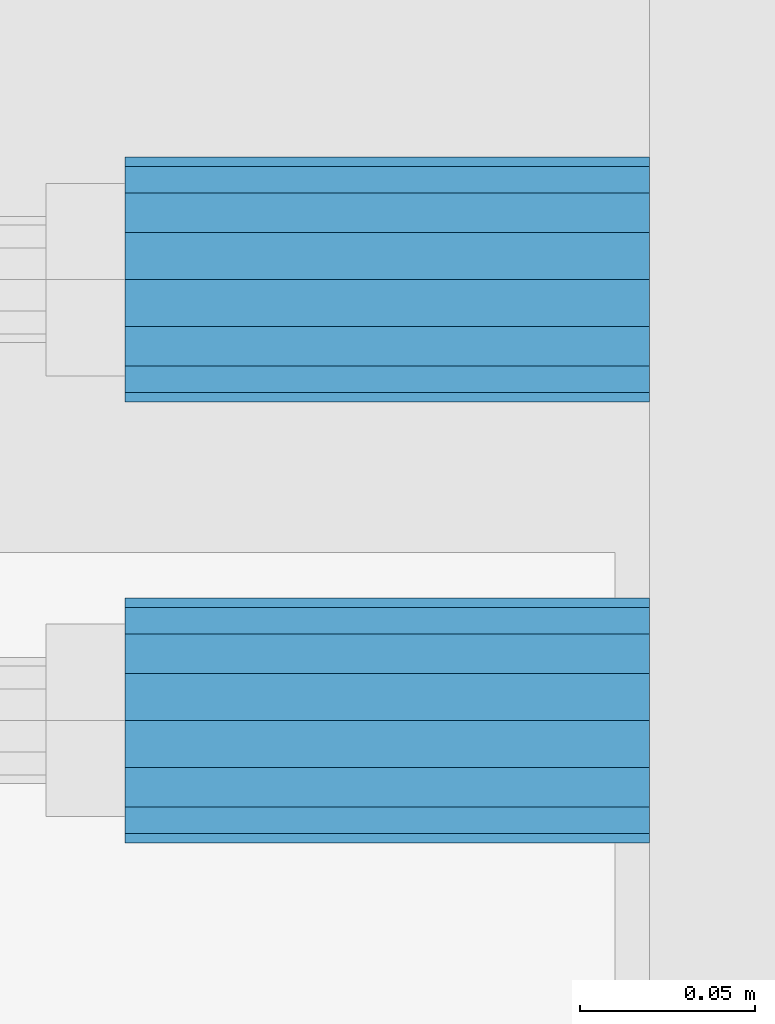
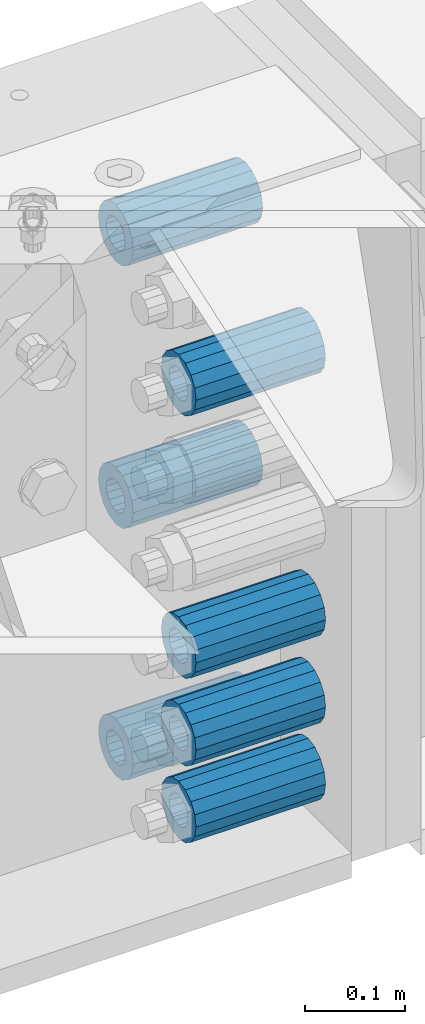
# One storey, part 134 of 193: 7 beams.
"""IFC2X3 building model written with IfcOpenShell, lengths in millimetres."""

from ifc_helpers import new_model, si_unit, frame, origin_with_axes, place, context, subcontext, project, spatial, faceted_brep, material, type_object, element, save


model = new_model("IFC2X3")

# Units and contexts
model_context = context("Model", 3, precision=1e-05, world=origin_with_axes())
body_context = subcontext(model_context, "Body", "Model", "MODEL_VIEW")
ifc_project = project(units=[si_unit("LENGTHUNIT", "METRE", prefix="MILLI"), si_unit("AREAUNIT", "SQUARE_METRE"), si_unit("VOLUMEUNIT", "CUBIC_METRE"), si_unit("MASSUNIT", "GRAM", prefix="KILO"), si_unit("TIMEUNIT", "SECOND"), si_unit("PLANEANGLEUNIT", "RADIAN"), si_unit("SOLIDANGLEUNIT", "STERADIAN"), si_unit("THERMODYNAMICTEMPERATUREUNIT", "DEGREE_CELSIUS"), si_unit("LUMINOUSINTENSITYUNIT", "LUMEN")], contexts=[model_context])

# Site, building, storey
site_placement = place(None, origin_with_axes())
site = spatial("IfcSite", under=ifc_project, at=site_placement, CompositionType="ELEMENT")
building_placement = place(site_placement, origin_with_axes())
building = spatial("IfcBuilding", under=site, at=building_placement, Name="Standard", CompositionType="ELEMENT")
storey_placement = place(building_placement, origin_with_axes())
storey = spatial("IfcBuildingStorey", under=building, at=storey_placement, Name="Undefined", CompositionType="ELEMENT", Elevation=0.0)

# Beams
ifc_material = material()
beam_type = type_object("IfcBeamType", PredefinedType="NOTDEFINED")
beam_1_placement = place(storey_placement, frame((-28573.0, 30063.0, -499.0), z_axis=(0.0, 0.0, 1.0), x_axis=(1.0, 0.0, 0.0)))
element("IfcBeam", 1, at=beam_1_placement, inside=storey, type_object=beam_type, material=ifc_material, context=body_context, shape_type="Brep", body=[
    faceted_brep([(-1.31236447487026e-07, -18.9999999995498, -6.26823748461902e-09), (0.0, -17.5537111177146, 7.27098521493673), (150.0, -17.5537111177146, 7.27098521493673), (150.0, -19.0, 0.0), (0.0, -13.4350288425449, 13.4350288425444), (150.0, -13.4350288425449, 13.4350288425444), (0.0, -7.27098521493826, 17.5537111177144), (150.0, -7.27098521493826, 17.5537111177144), (-6.29370333626866e-09, 4.49745130026713e-10, 18.9999999937318), (150.0, 0.0, 19.0), (0.0, 7.27098521493826, 17.5537111177144), (150.0, 7.27098521493826, 17.5537111177144), (0.0, 13.4350288425449, 13.4350288425444), (150.0, 13.4350288425449, 13.4350288425444), (0.0, 17.5537111177146, 7.27098521493673), (150.0, 17.5537111177146, 7.27098521493673), (1.33251887746155e-07, 19.0000000004502, -6.26823748461902e-09), (150.0, 19.0, 0.0), (0.0, 17.5537111177146, -7.27098521493673), (150.0, 17.5537111177146, -7.27098521493673), (0.0, 13.4350288425449, -13.4350288425444), (150.0, 13.4350288425449, -13.4350288425444), (0.0, 7.27098521493826, -17.5537111177144), (150.0, 7.27098521493826, -17.5537111177144), (8.30550561659038e-09, 4.49745130026713e-10, -19.0000000062682), (150.0, 0.0, -19.0), (0.0, -7.27098521493826, -17.5537111177144), (150.0, -7.27098521493826, -17.5537111177144), (0.0, -13.4350288425449, -13.4350288425444), (150.0, -13.4350288425449, -13.4350288425444), (0.0, -17.5537111177146, -7.27098521493673), (150.0, -17.5537111177146, -7.27098521493673), (-3.63797880709171e-12, -35.0, 0.0), (-3.63797880709171e-12, -32.335783637895, -13.3939201327776), (150.0, -32.3357836378964, -13.3939201327782), (150.0, -35.0, 0.0), (0.0, -24.7487373415292, -24.7487373415279), (150.0, -24.7487373415279, -24.7487373415292), (0.0, -13.3939201327781, -32.3357836378927), (150.0, -13.3939201327776, -32.335783637895), (0.0, 0.0, -35.0), (150.0, 0.0, -35.0), (0.0, 13.3939201327782, -32.3357836378927), (150.0, 13.3939201327776, -32.335783637895), (0.0, 24.7487373415292, -24.7487373415279), (150.0, 24.7487373415279, -24.7487373415291), (-3.63797880709171e-12, 32.335783637895, -13.3939201327776), (150.0, 32.3357836378964, -13.3939201327781), (-3.63797880709171e-12, 35.0, 0.0), (150.0, 35.0, 0.0), (-7.27595761418343e-12, 32.335783637895, 13.3939201327776), (150.0, 32.3357836378964, 13.3939201327781), (-7.27595761418343e-12, 24.7487373415292, 24.7487373415279), (150.0, 24.7487373415279, 24.7487373415292), (-7.27595761418343e-12, 13.3939201327781, 32.3357836378927), (150.0, 13.3939201327776, 32.335783637895), (-1.09139364212751e-11, 0.0, 35.0), (150.0, 0.0, 35.0), (-7.27595761418343e-12, -13.3939201327781, 32.3357836378927), (150.0, -13.3939201327776, 32.335783637895), (-7.27595761418343e-12, -24.7487373415292, 24.7487373415279), (150.0, -24.7487373415279, 24.7487373415292), (-7.27595761418343e-12, -32.335783637895, 13.3939201327776), (150.0, -32.3357836378964, 13.3939201327781)], [[[0, 1, 2, 3]], [[1, 4, 5, 2]], [[4, 6, 7, 5]], [[6, 8, 9, 7]], [[8, 10, 11, 9]], [[10, 12, 13, 11]], [[12, 14, 15, 13]], [[14, 16, 17, 15]], [[16, 18, 19, 17]], [[18, 20, 21, 19]], [[20, 22, 23, 21]], [[22, 24, 25, 23]], [[24, 26, 27, 25]], [[26, 28, 29, 27]], [[28, 30, 31, 29]], [[30, 0, 3, 31]], [[32, 33, 34, 35]], [[33, 36, 37, 34]], [[36, 38, 39, 37]], [[38, 40, 41, 39]], [[40, 42, 43, 41]], [[42, 44, 45, 43]], [[44, 46, 47, 45]], [[46, 48, 49, 47]], [[48, 50, 51, 49]], [[50, 52, 53, 51]], [[52, 54, 55, 53]], [[54, 56, 57, 55]], [[56, 58, 59, 57]], [[58, 60, 61, 59]], [[60, 62, 63, 61]], [[62, 32, 35, 63]], [[37, 39, 41, 43, 45, 47, 49, 51, 53, 55, 57, 59, 61, 63, 35, 34], [5, 7, 9, 11, 13, 15, 17, 19, 21, 23, 25, 27, 29, 31, 3, 2]], [[62, 60, 58, 56, 54, 52, 50, 48, 46, 44, 42, 40, 38, 36, 33, 32], [30, 28, 26, 24, 22, 20, 18, 16, 14, 12, 10, 8, 6, 4, 1, 0]]]),
])
beam_2_placement = place(storey_placement, frame((-28573.0, 29937.0, -285.0), z_axis=(0.0, 0.0, 1.0), x_axis=(1.0, 0.0, 0.0)))
element("IfcBeam", 2, at=beam_2_placement, inside=storey, type_object=beam_type, material=ifc_material, context=body_context, shape_type="Brep", body=[
    faceted_brep([(-1.31236447487026e-07, -18.9999999995498, -6.26823748461902e-09), (0.0, -17.5537111177146, 7.27098521493673), (150.0, -17.5537111177146, 7.27098521493673), (150.0, -19.0, 0.0), (0.0, -13.4350288425449, 13.4350288425444), (150.0, -13.4350288425449, 13.4350288425444), (0.0, -7.27098521493826, 17.5537111177144), (150.0, -7.27098521493826, 17.5537111177144), (-6.29370333626866e-09, 4.49745130026713e-10, 18.9999999937318), (150.0, 0.0, 19.0), (0.0, 7.27098521493826, 17.5537111177144), (150.0, 7.27098521493826, 17.5537111177144), (0.0, 13.4350288425449, 13.4350288425444), (150.0, 13.4350288425449, 13.4350288425444), (0.0, 17.5537111177146, 7.27098521493673), (150.0, 17.5537111177146, 7.27098521493673), (1.33251887746155e-07, 19.0000000004502, -6.26823748461902e-09), (150.0, 19.0, 0.0), (0.0, 17.5537111177146, -7.27098521493673), (150.0, 17.5537111177146, -7.27098521493673), (0.0, 13.4350288425449, -13.4350288425444), (150.0, 13.4350288425449, -13.4350288425444), (0.0, 7.27098521493826, -17.5537111177144), (150.0, 7.27098521493826, -17.5537111177144), (8.30550561659038e-09, 4.49745130026713e-10, -19.0000000062682), (150.0, 0.0, -19.0), (0.0, -7.27098521493826, -17.5537111177144), (150.0, -7.27098521493826, -17.5537111177144), (0.0, -13.4350288425449, -13.4350288425444), (150.0, -13.4350288425449, -13.4350288425444), (0.0, -17.5537111177146, -7.27098521493673), (150.0, -17.5537111177146, -7.27098521493673), (-3.63797880709171e-12, -35.0, 0.0), (-3.63797880709171e-12, -32.335783637895, -13.3939201327776), (150.0, -32.3357836378964, -13.3939201327782), (150.0, -35.0, 0.0), (0.0, -24.7487373415292, -24.7487373415279), (150.0, -24.7487373415279, -24.7487373415292), (0.0, -13.3939201327781, -32.3357836378927), (150.0, -13.3939201327776, -32.335783637895), (0.0, 0.0, -35.0), (150.0, 0.0, -35.0), (0.0, 13.3939201327782, -32.3357836378927), (150.0, 13.3939201327776, -32.335783637895), (0.0, 24.7487373415292, -24.7487373415279), (150.0, 24.7487373415279, -24.7487373415291), (-3.63797880709171e-12, 32.335783637895, -13.3939201327776), (150.0, 32.3357836378964, -13.3939201327781), (-3.63797880709171e-12, 35.0, 0.0), (150.0, 35.0, 0.0), (-7.27595761418343e-12, 32.335783637895, 13.3939201327776), (150.0, 32.3357836378964, 13.3939201327781), (-7.27595761418343e-12, 24.7487373415292, 24.7487373415279), (150.0, 24.7487373415279, 24.7487373415292), (-7.27595761418343e-12, 13.3939201327781, 32.3357836378927), (150.0, 13.3939201327776, 32.335783637895), (-1.09139364212751e-11, 0.0, 35.0), (150.0, 0.0, 35.0), (-7.27595761418343e-12, -13.3939201327781, 32.3357836378927), (150.0, -13.3939201327776, 32.335783637895), (-7.27595761418343e-12, -24.7487373415292, 24.7487373415279), (150.0, -24.7487373415279, 24.7487373415292), (-7.27595761418343e-12, -32.335783637895, 13.3939201327776), (150.0, -32.3357836378964, 13.3939201327781)], [[[0, 1, 2, 3]], [[1, 4, 5, 2]], [[4, 6, 7, 5]], [[6, 8, 9, 7]], [[8, 10, 11, 9]], [[10, 12, 13, 11]], [[12, 14, 15, 13]], [[14, 16, 17, 15]], [[16, 18, 19, 17]], [[18, 20, 21, 19]], [[20, 22, 23, 21]], [[22, 24, 25, 23]], [[24, 26, 27, 25]], [[26, 28, 29, 27]], [[28, 30, 31, 29]], [[30, 0, 3, 31]], [[32, 33, 34, 35]], [[33, 36, 37, 34]], [[36, 38, 39, 37]], [[38, 40, 41, 39]], [[40, 42, 43, 41]], [[42, 44, 45, 43]], [[44, 46, 47, 45]], [[46, 48, 49, 47]], [[48, 50, 51, 49]], [[50, 52, 53, 51]], [[52, 54, 55, 53]], [[54, 56, 57, 55]], [[56, 58, 59, 57]], [[58, 60, 61, 59]], [[60, 62, 63, 61]], [[62, 32, 35, 63]], [[37, 39, 41, 43, 45, 47, 49, 51, 53, 55, 57, 59, 61, 63, 35, 34], [5, 7, 9, 11, 13, 15, 17, 19, 21, 23, 25, 27, 29, 31, 3, 2]], [[62, 60, 58, 56, 54, 52, 50, 48, 46, 44, 42, 40, 38, 36, 33, 32], [30, 28, 26, 24, 22, 20, 18, 16, 14, 12, 10, 8, 6, 4, 1, 0]]]),
])
beam_3_placement = place(storey_placement, frame((-28573.0, 30063.0, -178.0), z_axis=(0.0, 0.0, 1.0), x_axis=(1.0, 0.0, 0.0)))
element("IfcBeam", 3, at=beam_3_placement, inside=storey, type_object=beam_type, material=ifc_material, context=body_context, shape_type="Brep", body=[
    faceted_brep([(-1.31236447487026e-07, -18.9999999995498, -6.26823748461902e-09), (0.0, -17.5537111177146, 7.27098521493673), (150.0, -17.5537111177146, 7.27098521493673), (150.0, -19.0, 0.0), (0.0, -13.4350288425449, 13.4350288425444), (150.0, -13.4350288425449, 13.4350288425444), (0.0, -7.27098521493826, 17.5537111177144), (150.0, -7.27098521493826, 17.5537111177144), (-6.29370333626866e-09, 4.49745130026713e-10, 18.9999999937318), (150.0, 0.0, 19.0), (0.0, 7.27098521493826, 17.5537111177144), (150.0, 7.27098521493826, 17.5537111177144), (0.0, 13.4350288425449, 13.4350288425444), (150.0, 13.4350288425449, 13.4350288425444), (0.0, 17.5537111177146, 7.27098521493673), (150.0, 17.5537111177146, 7.27098521493673), (1.33251887746155e-07, 19.0000000004502, -6.26823748461902e-09), (150.0, 19.0, 0.0), (0.0, 17.5537111177146, -7.27098521493673), (150.0, 17.5537111177146, -7.27098521493673), (0.0, 13.4350288425449, -13.4350288425444), (150.0, 13.4350288425449, -13.4350288425444), (0.0, 7.27098521493826, -17.5537111177144), (150.0, 7.27098521493826, -17.5537111177144), (8.30550561659038e-09, 4.49745130026713e-10, -19.0000000062682), (150.0, 0.0, -19.0), (0.0, -7.27098521493826, -17.5537111177144), (150.0, -7.27098521493826, -17.5537111177144), (0.0, -13.4350288425449, -13.4350288425444), (150.0, -13.4350288425449, -13.4350288425444), (0.0, -17.5537111177146, -7.27098521493673), (150.0, -17.5537111177146, -7.27098521493673), (-3.63797880709171e-12, -35.0, 0.0), (-3.63797880709171e-12, -32.335783637895, -13.3939201327776), (150.0, -32.3357836378964, -13.3939201327782), (150.0, -35.0, 0.0), (0.0, -24.7487373415292, -24.7487373415279), (150.0, -24.7487373415279, -24.7487373415292), (0.0, -13.3939201327781, -32.3357836378927), (150.0, -13.3939201327776, -32.335783637895), (0.0, 0.0, -35.0), (150.0, 0.0, -35.0), (0.0, 13.3939201327782, -32.3357836378927), (150.0, 13.3939201327776, -32.335783637895), (0.0, 24.7487373415292, -24.7487373415279), (150.0, 24.7487373415279, -24.7487373415291), (-3.63797880709171e-12, 32.335783637895, -13.3939201327776), (150.0, 32.3357836378964, -13.3939201327781), (-3.63797880709171e-12, 35.0, 0.0), (150.0, 35.0, 0.0), (-7.27595761418343e-12, 32.335783637895, 13.3939201327776), (150.0, 32.3357836378964, 13.3939201327781), (-7.27595761418343e-12, 24.7487373415292, 24.7487373415279), (150.0, 24.7487373415279, 24.7487373415292), (-7.27595761418343e-12, 13.3939201327781, 32.3357836378927), (150.0, 13.3939201327776, 32.335783637895), (-1.09139364212751e-11, 0.0, 35.0), (150.0, 0.0, 35.0), (-7.27595761418343e-12, -13.3939201327781, 32.3357836378927), (150.0, -13.3939201327776, 32.335783637895), (-7.27595761418343e-12, -24.7487373415292, 24.7487373415279), (150.0, -24.7487373415279, 24.7487373415292), (-7.27595761418343e-12, -32.335783637895, 13.3939201327776), (150.0, -32.3357836378964, 13.3939201327781)], [[[0, 1, 2, 3]], [[1, 4, 5, 2]], [[4, 6, 7, 5]], [[6, 8, 9, 7]], [[8, 10, 11, 9]], [[10, 12, 13, 11]], [[12, 14, 15, 13]], [[14, 16, 17, 15]], [[16, 18, 19, 17]], [[18, 20, 21, 19]], [[20, 22, 23, 21]], [[22, 24, 25, 23]], [[24, 26, 27, 25]], [[26, 28, 29, 27]], [[28, 30, 31, 29]], [[30, 0, 3, 31]], [[32, 33, 34, 35]], [[33, 36, 37, 34]], [[36, 38, 39, 37]], [[38, 40, 41, 39]], [[40, 42, 43, 41]], [[42, 44, 45, 43]], [[44, 46, 47, 45]], [[46, 48, 49, 47]], [[48, 50, 51, 49]], [[50, 52, 53, 51]], [[52, 54, 55, 53]], [[54, 56, 57, 55]], [[56, 58, 59, 57]], [[58, 60, 61, 59]], [[60, 62, 63, 61]], [[62, 32, 35, 63]], [[37, 39, 41, 43, 45, 47, 49, 51, 53, 55, 57, 59, 61, 63, 35, 34], [5, 7, 9, 11, 13, 15, 17, 19, 21, 23, 25, 27, 29, 31, 3, 2]], [[62, 60, 58, 56, 54, 52, 50, 48, 46, 44, 42, 40, 38, 36, 33, 32], [30, 28, 26, 24, 22, 20, 18, 16, 14, 12, 10, 8, 6, 4, 1, 0]]]),
])
beam_4_placement = place(storey_placement, frame((-28573.0, 29937.0, -606.0), z_axis=(0.0, 0.0, 1.0), x_axis=(1.0, 0.0, 0.0)))
element("IfcBeam", 4, at=beam_4_placement, inside=storey, type_object=beam_type, material=ifc_material, context=body_context, shape_type="Brep", body=[
    faceted_brep([(-1.31236447487026e-07, -18.9999999995498, -6.26823748461902e-09), (0.0, -17.5537111177146, 7.27098521493673), (150.0, -17.5537111177146, 7.27098521493673), (150.0, -19.0, 0.0), (0.0, -13.4350288425449, 13.4350288425444), (150.0, -13.4350288425449, 13.4350288425444), (0.0, -7.27098521493826, 17.5537111177144), (150.0, -7.27098521493826, 17.5537111177144), (-6.29370333626866e-09, 4.49745130026713e-10, 18.9999999937318), (150.0, 0.0, 19.0), (0.0, 7.27098521493826, 17.5537111177144), (150.0, 7.27098521493826, 17.5537111177144), (0.0, 13.4350288425449, 13.4350288425444), (150.0, 13.4350288425449, 13.4350288425444), (0.0, 17.5537111177146, 7.27098521493673), (150.0, 17.5537111177146, 7.27098521493673), (1.33251887746155e-07, 19.0000000004502, -6.26823748461902e-09), (150.0, 19.0, 0.0), (0.0, 17.5537111177146, -7.27098521493673), (150.0, 17.5537111177146, -7.27098521493673), (0.0, 13.4350288425449, -13.4350288425444), (150.0, 13.4350288425449, -13.4350288425444), (0.0, 7.27098521493826, -17.5537111177144), (150.0, 7.27098521493826, -17.5537111177144), (8.30550561659038e-09, 4.49745130026713e-10, -19.0000000062682), (150.0, 0.0, -19.0), (0.0, -7.27098521493826, -17.5537111177144), (150.0, -7.27098521493826, -17.5537111177144), (0.0, -13.4350288425449, -13.4350288425444), (150.0, -13.4350288425449, -13.4350288425444), (0.0, -17.5537111177146, -7.27098521493673), (150.0, -17.5537111177146, -7.27098521493673), (-3.63797880709171e-12, -35.0, 0.0), (-3.63797880709171e-12, -32.335783637895, -13.3939201327776), (150.0, -32.3357836378964, -13.3939201327782), (150.0, -35.0, 0.0), (0.0, -24.7487373415292, -24.7487373415279), (150.0, -24.7487373415279, -24.7487373415292), (0.0, -13.3939201327781, -32.3357836378927), (150.0, -13.3939201327776, -32.335783637895), (0.0, 0.0, -35.0), (150.0, 0.0, -35.0), (0.0, 13.3939201327782, -32.3357836378927), (150.0, 13.3939201327776, -32.335783637895), (0.0, 24.7487373415292, -24.7487373415279), (150.0, 24.7487373415279, -24.7487373415291), (-3.63797880709171e-12, 32.335783637895, -13.3939201327776), (150.0, 32.3357836378964, -13.3939201327781), (-3.63797880709171e-12, 35.0, 0.0), (150.0, 35.0, 0.0), (-7.27595761418343e-12, 32.335783637895, 13.3939201327776), (150.0, 32.3357836378964, 13.3939201327781), (-7.27595761418343e-12, 24.7487373415292, 24.7487373415279), (150.0, 24.7487373415279, 24.7487373415292), (-7.27595761418343e-12, 13.3939201327781, 32.3357836378927), (150.0, 13.3939201327776, 32.335783637895), (-1.09139364212751e-11, 0.0, 35.0), (150.0, 0.0, 35.0), (-7.27595761418343e-12, -13.3939201327781, 32.3357836378927), (150.0, -13.3939201327776, 32.335783637895), (-7.27595761418343e-12, -24.7487373415292, 24.7487373415279), (150.0, -24.7487373415279, 24.7487373415292), (-7.27595761418343e-12, -32.335783637895, 13.3939201327776), (150.0, -32.3357836378964, 13.3939201327781)], [[[0, 1, 2, 3]], [[1, 4, 5, 2]], [[4, 6, 7, 5]], [[6, 8, 9, 7]], [[8, 10, 11, 9]], [[10, 12, 13, 11]], [[12, 14, 15, 13]], [[14, 16, 17, 15]], [[16, 18, 19, 17]], [[18, 20, 21, 19]], [[20, 22, 23, 21]], [[22, 24, 25, 23]], [[24, 26, 27, 25]], [[26, 28, 29, 27]], [[28, 30, 31, 29]], [[30, 0, 3, 31]], [[32, 33, 34, 35]], [[33, 36, 37, 34]], [[36, 38, 39, 37]], [[38, 40, 41, 39]], [[40, 42, 43, 41]], [[42, 44, 45, 43]], [[44, 46, 47, 45]], [[46, 48, 49, 47]], [[48, 50, 51, 49]], [[50, 52, 53, 51]], [[52, 54, 55, 53]], [[54, 56, 57, 55]], [[56, 58, 59, 57]], [[58, 60, 61, 59]], [[60, 62, 63, 61]], [[62, 32, 35, 63]], [[37, 39, 41, 43, 45, 47, 49, 51, 53, 55, 57, 59, 61, 63, 35, 34], [5, 7, 9, 11, 13, 15, 17, 19, 21, 23, 25, 27, 29, 31, 3, 2]], [[62, 60, 58, 56, 54, 52, 50, 48, 46, 44, 42, 40, 38, 36, 33, 32], [30, 28, 26, 24, 22, 20, 18, 16, 14, 12, 10, 8, 6, 4, 1, 0]]]),
])
beam_5_placement = place(storey_placement, frame((-28573.0, 29937.0, -713.0), z_axis=(0.0, 0.0, 1.0), x_axis=(1.0, 0.0, 0.0)))
element("IfcBeam", 5, at=beam_5_placement, inside=storey, type_object=beam_type, material=ifc_material, context=body_context, shape_type="Brep", body=[
    faceted_brep([(-1.31236447487026e-07, -18.9999999995498, -6.26823748461902e-09), (0.0, -17.5537111177146, 7.27098521493673), (150.0, -17.5537111177146, 7.27098521493673), (150.0, -19.0, 0.0), (0.0, -13.4350288425449, 13.4350288425444), (150.0, -13.4350288425449, 13.4350288425444), (0.0, -7.27098521493826, 17.5537111177144), (150.0, -7.27098521493826, 17.5537111177144), (-6.29370333626866e-09, 4.49745130026713e-10, 18.9999999937318), (150.0, 0.0, 19.0), (0.0, 7.27098521493826, 17.5537111177144), (150.0, 7.27098521493826, 17.5537111177144), (0.0, 13.4350288425449, 13.4350288425444), (150.0, 13.4350288425449, 13.4350288425444), (0.0, 17.5537111177146, 7.27098521493673), (150.0, 17.5537111177146, 7.27098521493673), (1.33251887746155e-07, 19.0000000004502, -6.26823748461902e-09), (150.0, 19.0, 0.0), (0.0, 17.5537111177146, -7.27098521493673), (150.0, 17.5537111177146, -7.27098521493673), (0.0, 13.4350288425449, -13.4350288425444), (150.0, 13.4350288425449, -13.4350288425444), (0.0, 7.27098521493826, -17.5537111177144), (150.0, 7.27098521493826, -17.5537111177144), (8.30550561659038e-09, 4.49745130026713e-10, -19.0000000062682), (150.0, 0.0, -19.0), (0.0, -7.27098521493826, -17.5537111177144), (150.0, -7.27098521493826, -17.5537111177144), (0.0, -13.4350288425449, -13.4350288425444), (150.0, -13.4350288425449, -13.4350288425444), (0.0, -17.5537111177146, -7.27098521493673), (150.0, -17.5537111177146, -7.27098521493673), (-3.63797880709171e-12, -35.0, 0.0), (-3.63797880709171e-12, -32.335783637895, -13.3939201327776), (150.0, -32.3357836378964, -13.3939201327782), (150.0, -35.0, 0.0), (0.0, -24.7487373415292, -24.7487373415279), (150.0, -24.7487373415279, -24.7487373415292), (0.0, -13.3939201327781, -32.3357836378927), (150.0, -13.3939201327776, -32.335783637895), (0.0, 0.0, -35.0), (150.0, 0.0, -35.0), (0.0, 13.3939201327782, -32.3357836378927), (150.0, 13.3939201327776, -32.335783637895), (0.0, 24.7487373415292, -24.7487373415279), (150.0, 24.7487373415279, -24.7487373415291), (-3.63797880709171e-12, 32.335783637895, -13.3939201327776), (150.0, 32.3357836378964, -13.3939201327781), (-3.63797880709171e-12, 35.0, 0.0), (150.0, 35.0, 0.0), (-7.27595761418343e-12, 32.335783637895, 13.3939201327776), (150.0, 32.3357836378964, 13.3939201327781), (-7.27595761418343e-12, 24.7487373415292, 24.7487373415279), (150.0, 24.7487373415279, 24.7487373415292), (-7.27595761418343e-12, 13.3939201327781, 32.3357836378927), (150.0, 13.3939201327776, 32.335783637895), (-1.09139364212751e-11, 0.0, 35.0), (150.0, 0.0, 35.0), (-7.27595761418343e-12, -13.3939201327781, 32.3357836378927), (150.0, -13.3939201327776, 32.335783637895), (-7.27595761418343e-12, -24.7487373415292, 24.7487373415279), (150.0, -24.7487373415279, 24.7487373415292), (-7.27595761418343e-12, -32.335783637895, 13.3939201327776), (150.0, -32.3357836378964, 13.3939201327781)], [[[0, 1, 2, 3]], [[1, 4, 5, 2]], [[4, 6, 7, 5]], [[6, 8, 9, 7]], [[8, 10, 11, 9]], [[10, 12, 13, 11]], [[12, 14, 15, 13]], [[14, 16, 17, 15]], [[16, 18, 19, 17]], [[18, 20, 21, 19]], [[20, 22, 23, 21]], [[22, 24, 25, 23]], [[24, 26, 27, 25]], [[26, 28, 29, 27]], [[28, 30, 31, 29]], [[30, 0, 3, 31]], [[32, 33, 34, 35]], [[33, 36, 37, 34]], [[36, 38, 39, 37]], [[38, 40, 41, 39]], [[40, 42, 43, 41]], [[42, 44, 45, 43]], [[44, 46, 47, 45]], [[46, 48, 49, 47]], [[48, 50, 51, 49]], [[50, 52, 53, 51]], [[52, 54, 55, 53]], [[54, 56, 57, 55]], [[56, 58, 59, 57]], [[58, 60, 61, 59]], [[60, 62, 63, 61]], [[62, 32, 35, 63]], [[37, 39, 41, 43, 45, 47, 49, 51, 53, 55, 57, 59, 61, 63, 35, 34], [5, 7, 9, 11, 13, 15, 17, 19, 21, 23, 25, 27, 29, 31, 3, 2]], [[62, 60, 58, 56, 54, 52, 50, 48, 46, 44, 42, 40, 38, 36, 33, 32], [30, 28, 26, 24, 22, 20, 18, 16, 14, 12, 10, 8, 6, 4, 1, 0]]]),
])
beam_6_placement = place(storey_placement, frame((-28573.0, 30063.0, -807.0), z_axis=(0.0, 0.0, 1.0), x_axis=(1.0, 0.0, 0.0)))
element("IfcBeam", 6, at=beam_6_placement, inside=storey, type_object=beam_type, material=ifc_material, context=body_context, shape_type="Brep", body=[
    faceted_brep([(-1.31236447487026e-07, -18.9999999995498, -6.26823748461902e-09), (0.0, -17.5537111177146, 7.27098521493673), (150.0, -17.5537111177146, 7.27098521493673), (150.0, -19.0, 0.0), (0.0, -13.4350288425449, 13.4350288425444), (150.0, -13.4350288425449, 13.4350288425444), (0.0, -7.27098521493826, 17.5537111177144), (150.0, -7.27098521493826, 17.5537111177144), (-6.29370333626866e-09, 4.49745130026713e-10, 18.9999999937318), (150.0, 0.0, 19.0), (0.0, 7.27098521493826, 17.5537111177144), (150.0, 7.27098521493826, 17.5537111177144), (0.0, 13.4350288425449, 13.4350288425444), (150.0, 13.4350288425449, 13.4350288425444), (0.0, 17.5537111177146, 7.27098521493673), (150.0, 17.5537111177146, 7.27098521493673), (1.33251887746155e-07, 19.0000000004502, -6.26823748461902e-09), (150.0, 19.0, 0.0), (0.0, 17.5537111177146, -7.27098521493673), (150.0, 17.5537111177146, -7.27098521493673), (0.0, 13.4350288425449, -13.4350288425444), (150.0, 13.4350288425449, -13.4350288425444), (0.0, 7.27098521493826, -17.5537111177144), (150.0, 7.27098521493826, -17.5537111177144), (8.30550561659038e-09, 4.49745130026713e-10, -19.0000000062682), (150.0, 0.0, -19.0), (0.0, -7.27098521493826, -17.5537111177144), (150.0, -7.27098521493826, -17.5537111177144), (0.0, -13.4350288425449, -13.4350288425444), (150.0, -13.4350288425449, -13.4350288425444), (0.0, -17.5537111177146, -7.27098521493673), (150.0, -17.5537111177146, -7.27098521493673), (-3.63797880709171e-12, -35.0, 0.0), (-3.63797880709171e-12, -32.335783637895, -13.3939201327776), (150.0, -32.3357836378964, -13.3939201327782), (150.0, -35.0, 0.0), (0.0, -24.7487373415292, -24.7487373415279), (150.0, -24.7487373415279, -24.7487373415292), (0.0, -13.3939201327781, -32.3357836378927), (150.0, -13.3939201327776, -32.335783637895), (0.0, 0.0, -35.0), (150.0, 0.0, -35.0), (0.0, 13.3939201327782, -32.3357836378927), (150.0, 13.3939201327776, -32.335783637895), (0.0, 24.7487373415292, -24.7487373415279), (150.0, 24.7487373415279, -24.7487373415291), (-3.63797880709171e-12, 32.335783637895, -13.3939201327776), (150.0, 32.3357836378964, -13.3939201327781), (-3.63797880709171e-12, 35.0, 0.0), (150.0, 35.0, 0.0), (-7.27595761418343e-12, 32.335783637895, 13.3939201327776), (150.0, 32.3357836378964, 13.3939201327781), (-7.27595761418343e-12, 24.7487373415292, 24.7487373415279), (150.0, 24.7487373415279, 24.7487373415292), (-7.27595761418343e-12, 13.3939201327781, 32.3357836378927), (150.0, 13.3939201327776, 32.335783637895), (-1.09139364212751e-11, 0.0, 35.0), (150.0, 0.0, 35.0), (-7.27595761418343e-12, -13.3939201327781, 32.3357836378927), (150.0, -13.3939201327776, 32.335783637895), (-7.27595761418343e-12, -24.7487373415292, 24.7487373415279), (150.0, -24.7487373415279, 24.7487373415292), (-7.27595761418343e-12, -32.335783637895, 13.3939201327776), (150.0, -32.3357836378964, 13.3939201327781)], [[[0, 1, 2, 3]], [[1, 4, 5, 2]], [[4, 6, 7, 5]], [[6, 8, 9, 7]], [[8, 10, 11, 9]], [[10, 12, 13, 11]], [[12, 14, 15, 13]], [[14, 16, 17, 15]], [[16, 18, 19, 17]], [[18, 20, 21, 19]], [[20, 22, 23, 21]], [[22, 24, 25, 23]], [[24, 26, 27, 25]], [[26, 28, 29, 27]], [[28, 30, 31, 29]], [[30, 0, 3, 31]], [[32, 33, 34, 35]], [[33, 36, 37, 34]], [[36, 38, 39, 37]], [[38, 40, 41, 39]], [[40, 42, 43, 41]], [[42, 44, 45, 43]], [[44, 46, 47, 45]], [[46, 48, 49, 47]], [[48, 50, 51, 49]], [[50, 52, 53, 51]], [[52, 54, 55, 53]], [[54, 56, 57, 55]], [[56, 58, 59, 57]], [[58, 60, 61, 59]], [[60, 62, 63, 61]], [[62, 32, 35, 63]], [[37, 39, 41, 43, 45, 47, 49, 51, 53, 55, 57, 59, 61, 63, 35, 34], [5, 7, 9, 11, 13, 15, 17, 19, 21, 23, 25, 27, 29, 31, 3, 2]], [[62, 60, 58, 56, 54, 52, 50, 48, 46, 44, 42, 40, 38, 36, 33, 32], [30, 28, 26, 24, 22, 20, 18, 16, 14, 12, 10, 8, 6, 4, 1, 0]]]),
])
beam_7_placement = place(storey_placement, frame((-28573.0, 29937.0, -807.0), z_axis=(0.0, 0.0, 1.0), x_axis=(1.0, 0.0, 0.0)))
element("IfcBeam", 7, at=beam_7_placement, inside=storey, type_object=beam_type, material=ifc_material, context=body_context, shape_type="Brep", body=[
    faceted_brep([(-1.31236447487026e-07, -18.9999999995498, -6.26823748461902e-09), (0.0, -17.5537111177146, 7.27098521493673), (150.0, -17.5537111177146, 7.27098521493673), (150.0, -19.0, 0.0), (0.0, -13.4350288425449, 13.4350288425444), (150.0, -13.4350288425449, 13.4350288425444), (0.0, -7.27098521493826, 17.5537111177144), (150.0, -7.27098521493826, 17.5537111177144), (-6.29370333626866e-09, 4.49745130026713e-10, 18.9999999937318), (150.0, 0.0, 19.0), (0.0, 7.27098521493826, 17.5537111177144), (150.0, 7.27098521493826, 17.5537111177144), (0.0, 13.4350288425449, 13.4350288425444), (150.0, 13.4350288425449, 13.4350288425444), (0.0, 17.5537111177146, 7.27098521493673), (150.0, 17.5537111177146, 7.27098521493673), (1.33251887746155e-07, 19.0000000004502, -6.26823748461902e-09), (150.0, 19.0, 0.0), (0.0, 17.5537111177146, -7.27098521493673), (150.0, 17.5537111177146, -7.27098521493673), (0.0, 13.4350288425449, -13.4350288425444), (150.0, 13.4350288425449, -13.4350288425444), (0.0, 7.27098521493826, -17.5537111177144), (150.0, 7.27098521493826, -17.5537111177144), (8.30550561659038e-09, 4.49745130026713e-10, -19.0000000062682), (150.0, 0.0, -19.0), (0.0, -7.27098521493826, -17.5537111177144), (150.0, -7.27098521493826, -17.5537111177144), (0.0, -13.4350288425449, -13.4350288425444), (150.0, -13.4350288425449, -13.4350288425444), (0.0, -17.5537111177146, -7.27098521493673), (150.0, -17.5537111177146, -7.27098521493673), (-3.63797880709171e-12, -35.0, 0.0), (-3.63797880709171e-12, -32.335783637895, -13.3939201327776), (150.0, -32.3357836378964, -13.3939201327782), (150.0, -35.0, 0.0), (0.0, -24.7487373415292, -24.7487373415279), (150.0, -24.7487373415279, -24.7487373415292), (0.0, -13.3939201327781, -32.3357836378927), (150.0, -13.3939201327776, -32.335783637895), (0.0, 0.0, -35.0), (150.0, 0.0, -35.0), (0.0, 13.3939201327782, -32.3357836378927), (150.0, 13.3939201327776, -32.335783637895), (0.0, 24.7487373415292, -24.7487373415279), (150.0, 24.7487373415279, -24.7487373415291), (-3.63797880709171e-12, 32.335783637895, -13.3939201327776), (150.0, 32.3357836378964, -13.3939201327781), (-3.63797880709171e-12, 35.0, 0.0), (150.0, 35.0, 0.0), (-7.27595761418343e-12, 32.335783637895, 13.3939201327776), (150.0, 32.3357836378964, 13.3939201327781), (-7.27595761418343e-12, 24.7487373415292, 24.7487373415279), (150.0, 24.7487373415279, 24.7487373415292), (-7.27595761418343e-12, 13.3939201327781, 32.3357836378927), (150.0, 13.3939201327776, 32.335783637895), (-1.09139364212751e-11, 0.0, 35.0), (150.0, 0.0, 35.0), (-7.27595761418343e-12, -13.3939201327781, 32.3357836378927), (150.0, -13.3939201327776, 32.335783637895), (-7.27595761418343e-12, -24.7487373415292, 24.7487373415279), (150.0, -24.7487373415279, 24.7487373415292), (-7.27595761418343e-12, -32.335783637895, 13.3939201327776), (150.0, -32.3357836378964, 13.3939201327781)], [[[0, 1, 2, 3]], [[1, 4, 5, 2]], [[4, 6, 7, 5]], [[6, 8, 9, 7]], [[8, 10, 11, 9]], [[10, 12, 13, 11]], [[12, 14, 15, 13]], [[14, 16, 17, 15]], [[16, 18, 19, 17]], [[18, 20, 21, 19]], [[20, 22, 23, 21]], [[22, 24, 25, 23]], [[24, 26, 27, 25]], [[26, 28, 29, 27]], [[28, 30, 31, 29]], [[30, 0, 3, 31]], [[32, 33, 34, 35]], [[33, 36, 37, 34]], [[36, 38, 39, 37]], [[38, 40, 41, 39]], [[40, 42, 43, 41]], [[42, 44, 45, 43]], [[44, 46, 47, 45]], [[46, 48, 49, 47]], [[48, 50, 51, 49]], [[50, 52, 53, 51]], [[52, 54, 55, 53]], [[54, 56, 57, 55]], [[56, 58, 59, 57]], [[58, 60, 61, 59]], [[60, 62, 63, 61]], [[62, 32, 35, 63]], [[37, 39, 41, 43, 45, 47, 49, 51, 53, 55, 57, 59, 61, 63, 35, 34], [5, 7, 9, 11, 13, 15, 17, 19, 21, 23, 25, 27, 29, 31, 3, 2]], [[62, 60, 58, 56, 54, 52, 50, 48, 46, 44, 42, 40, 38, 36, 33, 32], [30, 28, 26, 24, 22, 20, 18, 16, 14, 12, 10, 8, 6, 4, 1, 0]]]),
])

save(model, "model.ifc")
